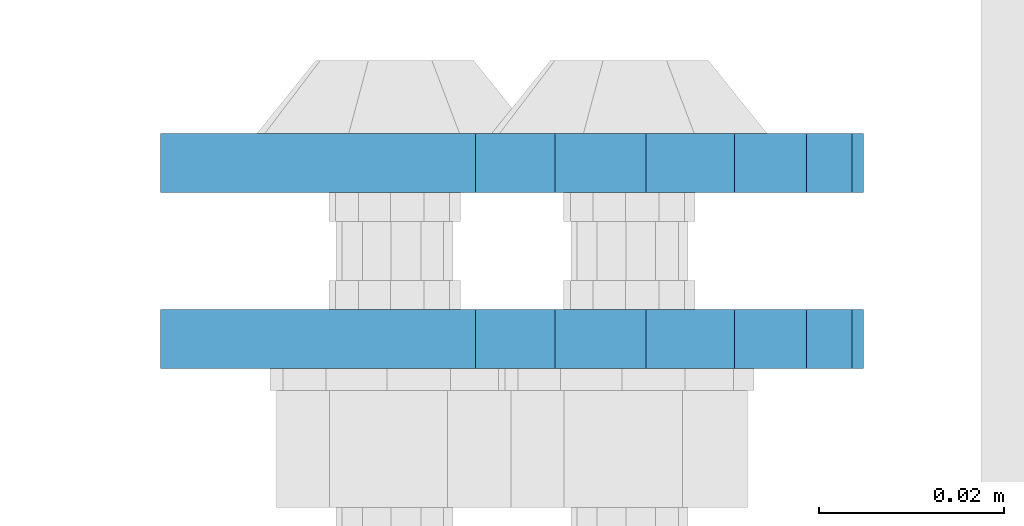
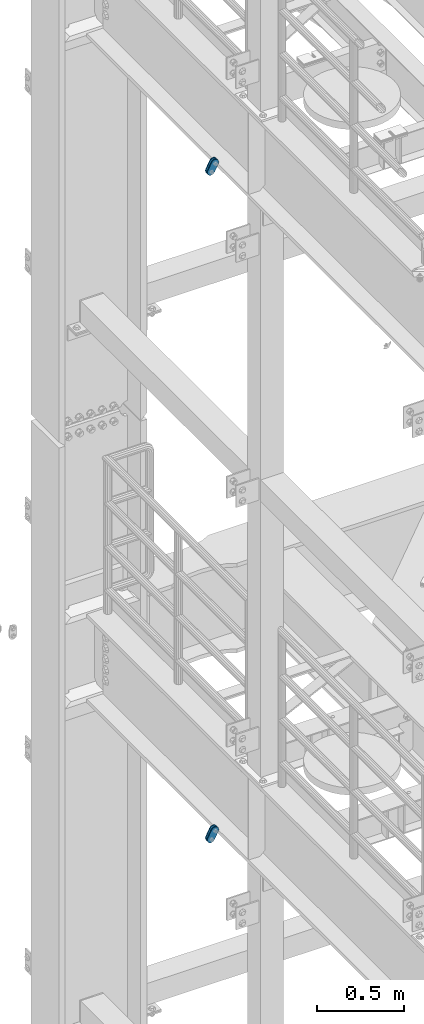
# One storey, part 1748 of 1876: 4 plates, 4 elements without a shape of their own.
"""IFC2X3 building model written with IfcOpenShell, lengths in millimetres."""

from ifc_helpers import new_model, si_unit, frame, origin_with_axes, place, context, subcontext, project, spatial, faceted_brep, material, type_object, element, aggregate, save


model = new_model("IFC2X3")

# Units and contexts
model_context = context("Model", 3, precision=1e-05, world=origin_with_axes())
body_context = subcontext(model_context, "Body", "Model", "MODEL_VIEW")
ifc_project = project(units=[si_unit("LENGTHUNIT", "METRE", prefix="MILLI"), si_unit("AREAUNIT", "SQUARE_METRE"), si_unit("VOLUMEUNIT", "CUBIC_METRE"), si_unit("MASSUNIT", "GRAM", prefix="KILO"), si_unit("TIMEUNIT", "SECOND"), si_unit("PLANEANGLEUNIT", "RADIAN"), si_unit("SOLIDANGLEUNIT", "STERADIAN"), si_unit("THERMODYNAMICTEMPERATUREUNIT", "DEGREE_CELSIUS"), si_unit("LUMINOUSINTENSITYUNIT", "LUMEN")], contexts=[model_context])

# Site, building, storey
site_placement = place(None, origin_with_axes())
site = spatial("IfcSite", under=ifc_project, at=site_placement, CompositionType="ELEMENT")
building_placement = place(site_placement, origin_with_axes())
building = spatial("IfcBuilding", under=site, at=building_placement, Name="Undefined", CompositionType="ELEMENT")
storey_placement = place(building_placement, origin_with_axes())
storey = spatial("IfcBuildingStorey", under=building, at=storey_placement, Name="Undefined", CompositionType="ELEMENT", Elevation=0.0)

# Assembly, plate
assembly_1_placement = place(storey_placement, origin_with_axes())
assembly_1 = element("IfcElementAssembly", 1, at=assembly_1_placement, inside=storey, Name="PLATE", AssemblyPlace="NOTDEFINED", PredefinedType="RIGID_FRAME")
ifc_material = material(Name="STEEL/A36")
plate_type = type_object("IfcPlateType", PredefinedType="NOTDEFINED")
plate_1_placement = place(assembly_1_placement, frame((-354.259224851122, 11674.4750022688, 17725.1776774809), z_axis=(0.894427191199916, 0.0, -0.447213595099958), x_axis=(-0.447213595099961, 6.99999707257306e-09, -0.894427191199915)))
plate_1 = element("IfcPlate", 2, at=plate_1_placement, type_object=plate_type, material=ifc_material, Name="PLATE", context=body_context, shape_type="Brep", body=[
    faceted_brep([(-8.59611645864788e-07, -3.17499999999654, 25.3999987589127), (1.93345873884391, -3.17499999999382, 35.1201580589886), (1.93345873884391, 3.17500000000564, 35.1201580589886), (-8.59611645864788e-07, 3.17500000000382, 25.3999987589132), (7.43948648259902, -3.17499999999109, 43.3605112870105), (7.43948648259902, 3.17500000000928, 43.3605112870105), (15.6798395242777, -3.17499999998654, 48.8665393096448), (15.6798395242777, 3.17500000001382, 48.8665393096448), (25.3999987589095, -3.17499999998199, 50.7999992370592), (25.3999987589095, 3.17500000001837, 50.7999992370592), (82.196130752618, -3.17499999998381, 50.7999992370605), (82.196130752618, 3.17500000001655, 50.7999992370642), (91.9162897887145, -3.17499999997926, 48.8665393918873), (91.9162897887145, 3.1750000000211, 48.8665393918909), (100.156642725027, -3.17499999997472, 43.3605115909359), (100.156642725027, 3.17500000002565, 43.3605115909395), (105.662670525982, -3.17499999997108, 35.1201586546285), (105.662670525986, 3.17500000002929, 35.1201586546358), (107.596130371159, -3.17499999996744, 25.3999996185757), (107.596130371159, 3.17500000003292, 25.3999996185794), (105.662670525981, -3.17499999996471, 15.6798405824902), (105.662670525981, 3.17500000003565, 15.6798405824939), (100.156642725024, -3.17499999996471, 7.43948764618654), (100.156642725025, 3.17500000003565, 7.43948764619017), (91.9162897887127, -3.17499999996562, 1.93345984522784), (91.9162897887127, 3.17500000003474, 1.93345984523148), (82.196130752618, -3.17499999996835, 4.54747350886464e-11), (82.196130752618, 3.1750000000311, 4.91127138957381e-11), (25.399998758905, -3.17499999999018, -8.64019966684282e-12), (25.399998758905, 3.17500000001019, -8.64019966684282e-12), (15.679839921364, -3.17499999999382, 1.9334597629304), (15.679839921364, 3.17500000000655, 1.9334597629304), (7.43948709043525, -3.17499999999654, 7.43948734220839), (7.43948709043525, 3.17500000000382, 7.43948734220885), (1.93345923228208, -3.17499999999654, 15.6798399868012), (1.93345923228208, 3.17500000000291, 15.6798399868012)], [[[0, 1, 2, 3]], [[1, 4, 5, 2]], [[4, 6, 7, 5]], [[6, 8, 9, 7]], [[8, 10, 11, 9]], [[10, 12, 13, 11]], [[12, 14, 15, 13]], [[14, 16, 17, 15]], [[16, 18, 19, 17]], [[18, 20, 21, 19]], [[20, 22, 23, 21]], [[22, 24, 25, 23]], [[24, 26, 27, 25]], [[26, 28, 29, 27]], [[28, 30, 31, 29]], [[30, 32, 33, 31]], [[32, 34, 35, 33]], [[34, 0, 3, 35]], [[5, 7, 9, 11, 13, 15, 17, 19, 21, 23, 25, 27, 29, 31, 33, 35, 3, 2]], [[34, 32, 30, 28, 26, 24, 22, 20, 18, 16, 14, 12, 10, 8, 6, 4, 1, 0]]]),
])
aggregate(assembly_1, [plate_1])

assembly_2_placement = place(storey_placement, origin_with_axes())
assembly_2 = element("IfcElementAssembly", 3, at=assembly_2_placement, inside=storey, Name="PLATE", AssemblyPlace="NOTDEFINED", PredefinedType="RIGID_FRAME")
plate_2_placement = place(assembly_2_placement, frame((-354.259224851122, 11693.5361985735, 17725.1776774809), z_axis=(0.894427191199916, 0.0, -0.447213595099958), x_axis=(-0.447213595099961, 6.99999707257306e-09, -0.894427191199915)))
plate_2 = element("IfcPlate", 4, at=plate_2_placement, type_object=plate_type, material=ifc_material, Name="PLATE", context=body_context, shape_type="Brep", body=[
    faceted_brep([(-8.59611645864788e-07, -3.17499999999654, 25.3999987589127), (1.93345873884391, -3.17499999999382, 35.1201580589886), (1.93345873884391, 3.17500000000564, 35.1201580589886), (-8.59611645864788e-07, 3.17500000000382, 25.3999987589132), (7.43948648259902, -3.17499999999109, 43.3605112870105), (7.43948648259902, 3.17500000000928, 43.3605112870105), (15.6798395242777, -3.17499999998654, 48.8665393096448), (15.6798395242777, 3.17500000001382, 48.8665393096448), (25.3999987589095, -3.17499999998199, 50.7999992370592), (25.3999987589095, 3.17500000001837, 50.7999992370592), (82.196130752618, -3.17499999998381, 50.7999992370605), (82.196130752618, 3.17500000001655, 50.7999992370642), (91.9162897887145, -3.17499999997926, 48.8665393918873), (91.9162897887145, 3.1750000000211, 48.8665393918909), (100.156642725027, -3.17499999997472, 43.3605115909359), (100.156642725027, 3.17500000002565, 43.3605115909395), (105.662670525982, -3.17499999997108, 35.1201586546285), (105.662670525986, 3.17500000002929, 35.1201586546358), (107.596130371159, -3.17499999996744, 25.3999996185757), (107.596130371159, 3.17500000003292, 25.3999996185794), (105.662670525981, -3.17499999996471, 15.6798405824902), (105.662670525981, 3.17500000003565, 15.6798405824939), (100.156642725024, -3.17499999996471, 7.43948764618654), (100.156642725025, 3.17500000003565, 7.43948764619017), (91.9162897887127, -3.17499999996562, 1.93345984522784), (91.9162897887127, 3.17500000003474, 1.93345984523148), (82.196130752618, -3.17499999996835, 4.54747350886464e-11), (82.196130752618, 3.1750000000311, 4.91127138957381e-11), (25.399998758905, -3.17499999999018, -8.64019966684282e-12), (25.399998758905, 3.17500000001019, -8.64019966684282e-12), (15.679839921364, -3.17499999999382, 1.9334597629304), (15.679839921364, 3.17500000000655, 1.9334597629304), (7.43948709043525, -3.17499999999654, 7.43948734220839), (7.43948709043525, 3.17500000000382, 7.43948734220885), (1.93345923228208, -3.17499999999654, 15.6798399868012), (1.93345923228208, 3.17500000000291, 15.6798399868012)], [[[0, 1, 2, 3]], [[1, 4, 5, 2]], [[4, 6, 7, 5]], [[6, 8, 9, 7]], [[8, 10, 11, 9]], [[10, 12, 13, 11]], [[12, 14, 15, 13]], [[14, 16, 17, 15]], [[16, 18, 19, 17]], [[18, 20, 21, 19]], [[20, 22, 23, 21]], [[22, 24, 25, 23]], [[24, 26, 27, 25]], [[26, 28, 29, 27]], [[28, 30, 31, 29]], [[30, 32, 33, 31]], [[32, 34, 35, 33]], [[34, 0, 3, 35]], [[5, 7, 9, 11, 13, 15, 17, 19, 21, 23, 25, 27, 29, 31, 33, 35, 3, 2]], [[34, 32, 30, 28, 26, 24, 22, 20, 18, 16, 14, 12, 10, 8, 6, 4, 1, 0]]]),
])
aggregate(assembly_2, [plate_2])

assembly_3_placement = place(storey_placement, origin_with_axes())
assembly_3 = element("IfcElementAssembly", 5, at=assembly_3_placement, inside=storey, Name="PLATE", AssemblyPlace="NOTDEFINED", PredefinedType="RIGID_FRAME")
plate_3_placement = place(assembly_3_placement, frame((-354.259224851123, 11674.4750022688, 13038.8776774809), z_axis=(0.894427191199916, 0.0, -0.447213595099958), x_axis=(-0.447213595099961, 6.99999707257306e-09, -0.894427191199915)))
plate_3 = element("IfcPlate", 6, at=plate_3_placement, type_object=plate_type, material=ifc_material, Name="PLATE", context=body_context, shape_type="Brep", body=[
    faceted_brep([(-8.59611645864788e-07, -3.17499999999654, 25.3999987589127), (1.93345873884391, -3.17499999999382, 35.1201580589886), (1.93345873884391, 3.17500000000564, 35.1201580589886), (-8.59611645864788e-07, 3.17500000000382, 25.3999987589132), (7.43948648259902, -3.17499999999109, 43.3605112870105), (7.43948648259902, 3.17500000000928, 43.3605112870105), (15.6798395242777, -3.17499999998654, 48.8665393096448), (15.6798395242777, 3.17500000001382, 48.8665393096448), (25.3999987589095, -3.17499999998199, 50.7999992370592), (25.3999987589095, 3.17500000001837, 50.7999992370592), (82.196130752618, -3.17499999998381, 50.7999992370605), (82.196130752618, 3.17500000001655, 50.7999992370642), (91.9162897887145, -3.17499999997926, 48.8665393918873), (91.9162897887145, 3.1750000000211, 48.8665393918909), (100.156642725027, -3.17499999997472, 43.3605115909359), (100.156642725027, 3.17500000002565, 43.3605115909395), (105.662670525982, -3.17499999997108, 35.1201586546285), (105.662670525986, 3.17500000002929, 35.1201586546358), (107.596130371159, -3.17499999996744, 25.3999996185757), (107.596130371159, 3.17500000003292, 25.3999996185794), (105.662670525981, -3.17499999996471, 15.6798405824902), (105.662670525981, 3.17500000003565, 15.6798405824939), (100.156642725024, -3.17499999996471, 7.43948764618654), (100.156642725025, 3.17500000003565, 7.43948764619017), (91.9162897887127, -3.17499999996562, 1.93345984522784), (91.9162897887127, 3.17500000003474, 1.93345984523148), (82.196130752618, -3.17499999996835, 4.54747350886464e-11), (82.196130752618, 3.1750000000311, 4.91127138957381e-11), (25.399998758905, -3.17499999999018, -8.64019966684282e-12), (25.399998758905, 3.17500000001019, -8.64019966684282e-12), (15.679839921364, -3.17499999999382, 1.9334597629304), (15.679839921364, 3.17500000000655, 1.9334597629304), (7.43948709043525, -3.17499999999654, 7.43948734220839), (7.43948709043525, 3.17500000000382, 7.43948734220885), (1.93345923228208, -3.17499999999654, 15.6798399868012), (1.93345923228208, 3.17500000000291, 15.6798399868012)], [[[0, 1, 2, 3]], [[1, 4, 5, 2]], [[4, 6, 7, 5]], [[6, 8, 9, 7]], [[8, 10, 11, 9]], [[10, 12, 13, 11]], [[12, 14, 15, 13]], [[14, 16, 17, 15]], [[16, 18, 19, 17]], [[18, 20, 21, 19]], [[20, 22, 23, 21]], [[22, 24, 25, 23]], [[24, 26, 27, 25]], [[26, 28, 29, 27]], [[28, 30, 31, 29]], [[30, 32, 33, 31]], [[32, 34, 35, 33]], [[34, 0, 3, 35]], [[5, 7, 9, 11, 13, 15, 17, 19, 21, 23, 25, 27, 29, 31, 33, 35, 3, 2]], [[34, 32, 30, 28, 26, 24, 22, 20, 18, 16, 14, 12, 10, 8, 6, 4, 1, 0]]]),
])
aggregate(assembly_3, [plate_3])

assembly_4_placement = place(storey_placement, origin_with_axes())
assembly_4 = element("IfcElementAssembly", 7, at=assembly_4_placement, inside=storey, Name="PLATE", AssemblyPlace="NOTDEFINED", PredefinedType="RIGID_FRAME")
plate_4_placement = place(assembly_4_placement, frame((-354.259224851123, 11693.5361985735, 13038.8776774809), z_axis=(0.894427191199916, 0.0, -0.447213595099958), x_axis=(-0.447213595099961, 6.99999707257306e-09, -0.894427191199915)))
plate_4 = element("IfcPlate", 8, at=plate_4_placement, type_object=plate_type, material=ifc_material, Name="PLATE", context=body_context, shape_type="Brep", body=[
    faceted_brep([(-8.59611645864788e-07, -3.17499999999654, 25.3999987589127), (1.93345873884391, -3.17499999999382, 35.1201580589886), (1.93345873884391, 3.17500000000564, 35.1201580589886), (-8.59611645864788e-07, 3.17500000000382, 25.3999987589132), (7.43948648259902, -3.17499999999109, 43.3605112870105), (7.43948648259902, 3.17500000000928, 43.3605112870105), (15.6798395242777, -3.17499999998654, 48.8665393096448), (15.6798395242777, 3.17500000001382, 48.8665393096448), (25.3999987589095, -3.17499999998199, 50.7999992370592), (25.3999987589095, 3.17500000001837, 50.7999992370592), (82.196130752618, -3.17499999998381, 50.7999992370605), (82.196130752618, 3.17500000001655, 50.7999992370642), (91.9162897887145, -3.17499999997926, 48.8665393918873), (91.9162897887145, 3.1750000000211, 48.8665393918909), (100.156642725027, -3.17499999997472, 43.3605115909359), (100.156642725027, 3.17500000002565, 43.3605115909395), (105.662670525982, -3.17499999997108, 35.1201586546285), (105.662670525986, 3.17500000002929, 35.1201586546358), (107.596130371159, -3.17499999996744, 25.3999996185757), (107.596130371159, 3.17500000003292, 25.3999996185794), (105.662670525981, -3.17499999996471, 15.6798405824902), (105.662670525981, 3.17500000003565, 15.6798405824939), (100.156642725024, -3.17499999996471, 7.43948764618654), (100.156642725025, 3.17500000003565, 7.43948764619017), (91.9162897887127, -3.17499999996562, 1.93345984522784), (91.9162897887127, 3.17500000003474, 1.93345984523148), (82.196130752618, -3.17499999996835, 4.54747350886464e-11), (82.196130752618, 3.1750000000311, 4.91127138957381e-11), (25.399998758905, -3.17499999999018, -8.64019966684282e-12), (25.399998758905, 3.17500000001019, -8.64019966684282e-12), (15.679839921364, -3.17499999999382, 1.9334597629304), (15.679839921364, 3.17500000000655, 1.9334597629304), (7.43948709043525, -3.17499999999654, 7.43948734220839), (7.43948709043525, 3.17500000000382, 7.43948734220885), (1.93345923228208, -3.17499999999654, 15.6798399868012), (1.93345923228208, 3.17500000000291, 15.6798399868012)], [[[0, 1, 2, 3]], [[1, 4, 5, 2]], [[4, 6, 7, 5]], [[6, 8, 9, 7]], [[8, 10, 11, 9]], [[10, 12, 13, 11]], [[12, 14, 15, 13]], [[14, 16, 17, 15]], [[16, 18, 19, 17]], [[18, 20, 21, 19]], [[20, 22, 23, 21]], [[22, 24, 25, 23]], [[24, 26, 27, 25]], [[26, 28, 29, 27]], [[28, 30, 31, 29]], [[30, 32, 33, 31]], [[32, 34, 35, 33]], [[34, 0, 3, 35]], [[5, 7, 9, 11, 13, 15, 17, 19, 21, 23, 25, 27, 29, 31, 33, 35, 3, 2]], [[34, 32, 30, 28, 26, 24, 22, 20, 18, 16, 14, 12, 10, 8, 6, 4, 1, 0]]]),
])
aggregate(assembly_4, [plate_4])

save(model, "model.ifc")
